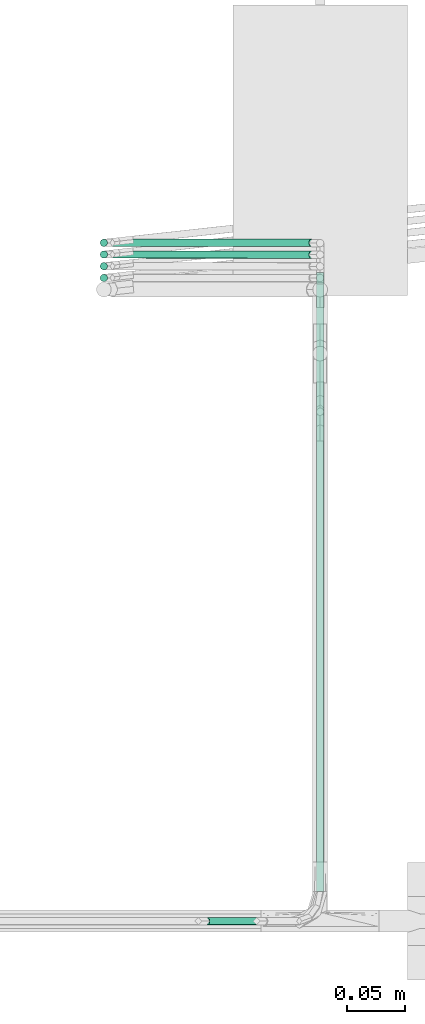
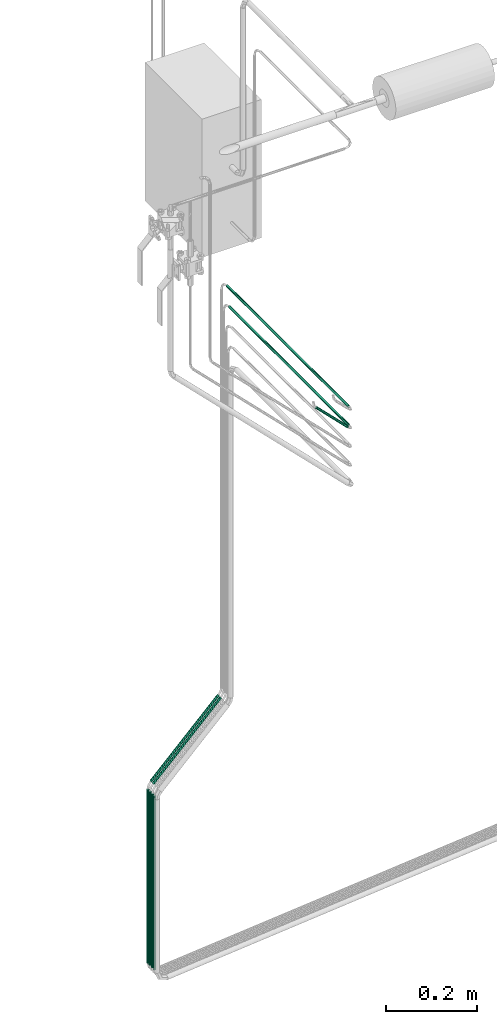
# One storey, part 13 of 45: 9 flow segments.
"""IFC2X3 building model written with IfcOpenShell, lengths in millimetres."""

from ifc_helpers import new_model, entity, si_unit, converted_unit, derived_unit, direction, frame, origin, origin_2d_with_axis, place, context, subcontext, project, spatial, circle, extrude, type_object, element, save


model = new_model("IFC2X3")

# Units and contexts
model_context = context("Model", 3, precision=0.01, world=origin(), true_north=direction((6.12303176911189e-17, 1.0)))
body_context = subcontext(model_context, "Body", "Model", "MODEL_VIEW")
ifc_project = project(units=[si_unit("LENGTHUNIT", "METRE", prefix="MILLI"), si_unit("AREAUNIT", "SQUARE_METRE"), si_unit("VOLUMEUNIT", "CUBIC_METRE"), converted_unit("PLANEANGLEUNIT", "DEGREE", entity("IfcRatioMeasure", 0.0174532925199433), si_unit("PLANEANGLEUNIT", "RADIAN"), dimensions=[0, 0, 0, 0, 0, 0, 0]), si_unit("MASSUNIT", "GRAM", prefix="KILO"), derived_unit("MASSDENSITYUNIT", [(si_unit("MASSUNIT", "GRAM", prefix="KILO"), 1), (si_unit("LENGTHUNIT", "METRE"), -3)]), derived_unit("MOMENTOFINERTIAUNIT", [(si_unit("LENGTHUNIT", "METRE"), 4)]), si_unit("TIMEUNIT", "SECOND"), si_unit("FREQUENCYUNIT", "HERTZ"), si_unit("THERMODYNAMICTEMPERATUREUNIT", "DEGREE_CELSIUS"), derived_unit("THERMALTRANSMITTANCEUNIT", [(si_unit("MASSUNIT", "GRAM", prefix="KILO"), 1), (si_unit("THERMODYNAMICTEMPERATUREUNIT", "KELVIN"), -1), (si_unit("TIMEUNIT", "SECOND"), -3)]), derived_unit("VOLUMETRICFLOWRATEUNIT", [(si_unit("LENGTHUNIT", "METRE"), 3), (si_unit("TIMEUNIT", "SECOND"), -1)]), derived_unit("MASSFLOWRATEUNIT", [(si_unit("MASSUNIT", "GRAM", prefix="KILO"), 1), (si_unit("TIMEUNIT", "SECOND"), -1)]), derived_unit("ROTATIONALFREQUENCYUNIT", [(si_unit("TIMEUNIT", "SECOND"), -1)]), si_unit("ELECTRICCURRENTUNIT", "AMPERE"), si_unit("ELECTRICVOLTAGEUNIT", "VOLT"), si_unit("POWERUNIT", "WATT"), si_unit("FORCEUNIT", "NEWTON", prefix="KILO"), si_unit("ILLUMINANCEUNIT", "LUX"), si_unit("LUMINOUSFLUXUNIT", "LUMEN"), si_unit("LUMINOUSINTENSITYUNIT", "CANDELA"), derived_unit("USERDEFINED", [(si_unit("MASSUNIT", "GRAM", prefix="KILO"), -1), (si_unit("LENGTHUNIT", "METRE"), -2), (si_unit("TIMEUNIT", "SECOND"), 3), (si_unit("LUMINOUSFLUXUNIT", "LUMEN"), 1)]), derived_unit("LINEARVELOCITYUNIT", [(si_unit("LENGTHUNIT", "METRE"), 1), (si_unit("TIMEUNIT", "SECOND"), -1)]), si_unit("PRESSUREUNIT", "PASCAL"), derived_unit("USERDEFINED", [(si_unit("LENGTHUNIT", "METRE"), -2), (si_unit("MASSUNIT", "GRAM", prefix="KILO"), 1), (si_unit("TIMEUNIT", "SECOND"), -2)]), derived_unit("LINEARFORCEUNIT", [(si_unit("MASSUNIT", "GRAM", prefix="KILO"), 1), (si_unit("LENGTHUNIT", "METRE"), 1), (si_unit("TIMEUNIT", "SECOND"), -2), (si_unit("LENGTHUNIT", "METRE"), -1)]), derived_unit("PLANARFORCEUNIT", [(si_unit("MASSUNIT", "GRAM", prefix="KILO"), 1), (si_unit("LENGTHUNIT", "METRE"), 1), (si_unit("TIMEUNIT", "SECOND"), -2), (si_unit("LENGTHUNIT", "METRE"), -2)])], contexts=[model_context])

# Site, building, storey
site_placement = place(None, frame((-24836.06, 8968.75, 0.0)))
site = spatial("IfcSite", under=ifc_project, at=site_placement, CompositionType="ELEMENT")
building_placement = place(site_placement, origin())
building = spatial("IfcBuilding", under=site, at=building_placement, CompositionType="ELEMENT")
storey_placement = place(building_placement, frame((0.0, 0.0, -4200.0)))
storey = spatial("IfcBuildingStorey", under=building, at=storey_placement, CompositionType="ELEMENT", Elevation=-4200.0)

# Flow segments
pipe_segment_type = type_object("IfcPipeSegmentType", PredefinedType="NOTDEFINED")
flow_segment_1_placement = place(storey_placement, frame((69468.46, -8368.67, 103.6)))
element("IfcFlowSegment", 1, at=flow_segment_1_placement, inside=storey, type_object=pipe_segment_type, context=body_context, shape_type="SweptSolid", body=[
    extrude(circle(Radius=3.175, at=origin_2d_with_axis()), frame((3.84, 4.95, 3.84), z_axis=(0.707106582771788, -0.000749133915421754, 0.707106582771779), x_axis=(0.00105943504594481, 0.999999438798534, 0.0)), (0.0, 0.0, 1.0), 242.072833751217),
])
flow_segment_2_placement = place(storey_placement, frame((69646.14, -8911.84, 1331.28)))
element("IfcFlowSegment", 2, at=flow_segment_2_placement, inside=storey, type_object=pipe_segment_type, context=body_context, shape_type="SweptSolid", body=[
    extrude(circle(Radius=3.175, at=origin_2d_with_axis()), frame((4.77, 0.0, 4.77), z_axis=(0.0, 1.0, 0.0), x_axis=(-1.0, 0.0, 0.0)), (0.0, 0.0, 1.0), 522.548419713841),
])
flow_segment_3_placement = place(storey_placement, frame((69549.85, -8942.01, 1350.17)))
element("IfcFlowSegment", 3, at=flow_segment_3_placement, inside=storey, type_object=pipe_segment_type, context=body_context, shape_type="SweptSolid", body=[
    extrude(circle(Radius=3.175, at=origin_2d_with_axis()), frame((83.1, 4.77, 3.84), z_axis=(-0.707106781186526, 0.0, 0.707106781186569), x_axis=(0.0, 1.0, 0.0)), (0.0, 0.0, 1.0), 112.090254897692),
])
flow_segment_4_placement = place(storey_placement, frame((69468.46, -8358.42, 103.6)))
element("IfcFlowSegment", 4, at=flow_segment_4_placement, inside=storey, type_object=pipe_segment_type, context=body_context, shape_type="SweptSolid", body=[
    extrude(circle(Radius=3.175, at=origin_2d_with_axis()), frame((3.84, 4.77, 3.84), z_axis=(0.707106781186543, 0.0, 0.707106781186552), x_axis=(0.0, -1.0, 0.0)), (0.0, 0.0, 1.0), 242.072765822202),
])
flow_segment_5_placement = place(storey_placement, frame((69646.14, -8911.84, 1381.28)))
element("IfcFlowSegment", 5, at=flow_segment_5_placement, inside=storey, type_object=pipe_segment_type, context=body_context, shape_type="SweptSolid", body=[
    extrude(circle(Radius=3.175, at=origin_2d_with_axis()), frame((4.77, 0.0, 4.77), z_axis=(0.0, 1.0, 0.0), x_axis=(-1.0, 0.0, 0.0)), (0.0, 0.0, 1.0), 532.548419713841),
])
flow_segment_6_placement = place(storey_placement, frame((69460.09, -8358.42, -374.6)))
element("IfcFlowSegment", 6, at=flow_segment_6_placement, inside=storey, type_object=pipe_segment_type, context=body_context, shape_type="SweptSolid", body=[
    extrude(circle(Radius=3.175, at=origin_2d_with_axis()), frame((4.77, 4.77, 0.0), z_axis=(0.0, 0.0, 1.0), x_axis=(-1.0, 0.0, 0.0)), (0.0, 0.0, 1.0), 464.078975515744),
])
for number, where in (
    (7, (69460.09, -8368.48, -374.6)),
    (8, (69460.09, -8378.55, -374.6)),
):
    element("IfcFlowSegment", number, at=place(storey_placement, frame(where)), inside=storey, type_object=pipe_segment_type, context=body_context, shape_type="SweptSolid", body=[
        extrude(circle(Radius=3.175, at=origin_2d_with_axis()), frame((4.77, 4.77, 0.0), z_axis=(0.0, 0.0, 1.0), x_axis=(-1.0, 0.0, 0.0)), (0.0, 0.0, 1.0), 464.078975515751),
    ])
flow_segment_7_placement = place(storey_placement, frame((69460.09, -8388.61, -374.6)))
element("IfcFlowSegment", 9, at=flow_segment_7_placement, inside=storey, type_object=pipe_segment_type, context=body_context, shape_type="SweptSolid", body=[
    extrude(circle(Radius=3.175, at=origin_2d_with_axis()), frame((4.77, 4.77, 0.0), z_axis=(0.0, 0.0, 1.0), x_axis=(-1.0, 0.0, 0.0)), (0.0, 0.0, 1.0), 464.07897551576),
])

save(model, "model.ifc")
